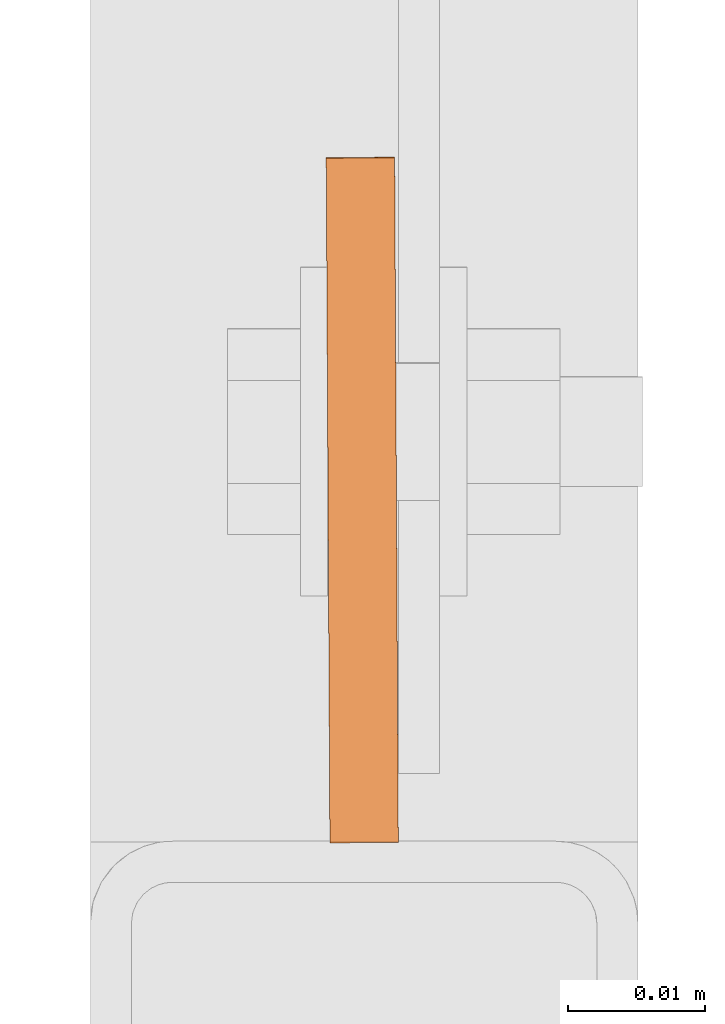
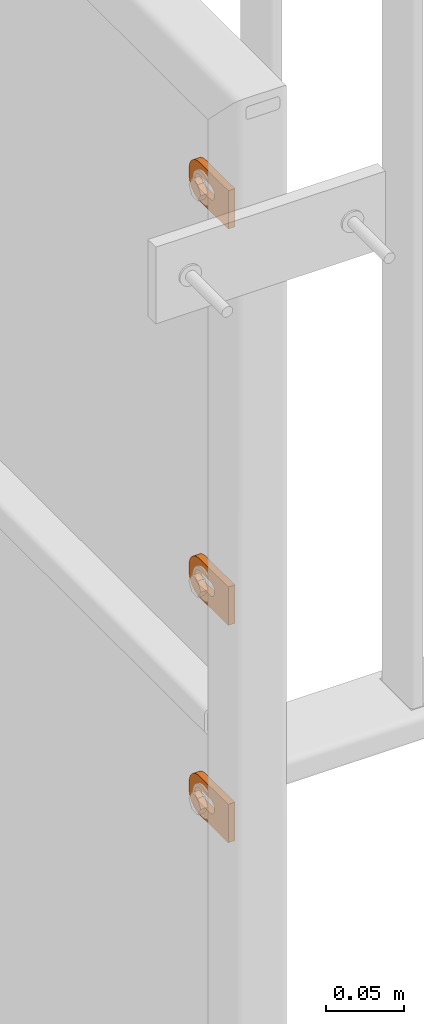
# One storey, part 141 of 156: 3 proxies, 1 element without a shape of its own.
"""IFC2X3 building model written with IfcOpenShell, lengths in millimetres."""

from ifc_helpers import new_model, si_unit, frame, origin_with_axes, place, context, subcontext, project, spatial, faceted_brep, material, type_object, element, aggregate, save


model = new_model("IFC2X3")

# Units and contexts
model_context = context("Model", 3, precision=1e-05, world=origin_with_axes())
body_context = subcontext(model_context, "Body", "Model", "MODEL_VIEW")
ifc_project = project(units=[si_unit("LENGTHUNIT", "METRE", prefix="MILLI"), si_unit("AREAUNIT", "SQUARE_METRE"), si_unit("VOLUMEUNIT", "CUBIC_METRE"), si_unit("MASSUNIT", "GRAM", prefix="KILO"), si_unit("TIMEUNIT", "SECOND"), si_unit("PLANEANGLEUNIT", "RADIAN"), si_unit("SOLIDANGLEUNIT", "STERADIAN"), si_unit("THERMODYNAMICTEMPERATUREUNIT", "DEGREE_CELSIUS"), si_unit("LUMINOUSINTENSITYUNIT", "LUMEN")], contexts=[model_context])

# Site, building, storey
site_placement = place(None, origin_with_axes())
site = spatial("IfcSite", under=ifc_project, at=site_placement, CompositionType="ELEMENT")
building_placement = place(site_placement, origin_with_axes())
building = spatial("IfcBuilding", under=site, at=building_placement, Name="Undefined", CompositionType="ELEMENT")
storey_placement = place(building_placement, origin_with_axes())
storey = spatial("IfcBuildingStorey", under=building, at=storey_placement, Name="Undefined", CompositionType="ELEMENT", Elevation=0.0)

# Assembly, proxies
assembly_placement = place(storey_placement, origin_with_axes())
assembly = element("IfcElementAssembly", 1, at=assembly_placement, inside=storey, AssemblyPlace="NOTDEFINED", PredefinedType="RIGID_FRAME")
ifc_material = material(Name="STEEL/S235JR")
building_element_proxy_type = type_object("IfcBuildingElementProxyType", Name="50", PredefinedType="NOTDEFINED")
proxy_1_placement = place(assembly_placement, frame((34000.0, 20157.8969120076, 4384.99382245688), z_axis=(0.999985556002151, 0.00537473600001249, 0.0), x_axis=(-0.00537473600001187, 0.999985556002151, 1.19999999540802e-08)))
proxy_1 = element("IfcBuildingElementProxy", 2, at=proxy_1_placement, type_object=building_element_proxy_type, material=ifc_material, ObjectType="50", CompositionType="ELEMENT", context=body_context, shape_type="Brep", body=[
    faceted_brep([(37.0000004768226, -5.50000056624776, -2.49999994410609), (23.0000000446889, -5.50000056624594, -2.49999994410973), (23.0000000446889, -5.50000056624594, 2.49999994413156), (37.000000476819, -5.50000056624776, 2.49999994413338), (21.9270028173814, -5.39431966841403, -2.49999994410973), (21.9270028173778, -5.39431966841403, 2.49999994412792), (20.895240828384, -5.0813375413436, -2.49999994411155), (20.895240828384, -5.0813375413436, 2.49999994412974), (19.9443642049955, -4.5730831474084, -2.49999994410973), (19.9443642049919, -4.5730831474084, 2.49999994412792), (19.1109124571012, -3.88908818364325, -2.49999994411155), (19.1109124571012, -3.88908818364325, 2.49999994412792), (18.4269174933361, -3.05563643574806, -2.49999994411155), (18.4269174933361, -3.05563643574806, 2.4999999441261), (17.9186630994009, -2.1047579497108, -2.49999994411155), (17.9186630994009, -2.1047579497108, 2.49999994412428), (17.6056809723377, -1.07299596071425, -2.49999994411337), (17.6056809723341, -1.07299596071425, 2.4999999441261), (17.5000000745022, 3.3527521736687e-07, -2.49999994411519), (17.5000000745058, 3.3527521736687e-07, 2.49999994412428), (17.6056809723377, 1.07299663126287, -2.49999994411701), (17.6056809723377, 1.07299663126287, 2.49999994412428), (17.9186630994154, 2.10475862026124, -2.49999994411701), (17.9186630994118, 2.10475862026124, 2.49999994412246), (18.426917493347, 3.05563617497592, -2.49999994411701), (18.426917493347, 3.05563617497592, 2.49999994412246), (19.1109124571158, 3.88908699154672, -2.49999994411883), (19.1109124571121, 3.88908699154672, 2.49999994412065), (19.9443642050101, 4.57308288663444, -2.49999994411701), (19.9443642050064, 4.57308288663444, 2.49999994412065), (20.8952408283985, 5.08133728056964, -2.49999994411883), (20.8952408283985, 5.08133728056964, 2.49999994412065), (21.9270028173996, 5.39431940764007, -2.49999994411883), (21.927002817396, 5.39431940764007, 2.49999994412065), (23.0000000447108, 5.50000030547199, -2.49999994411883), (23.0000000447071, 5.50000030547199, 2.49999994412246), (37.0000004768408, 5.50000030547017, -2.49999994411519), (37.0000004768408, 5.50000030547017, 2.49999994412428), (38.0729958415031, 5.39431940763825, -2.49999994411519), (38.0729958414995, 5.39431940763825, 2.49999994412428), (39.1047596931458, 5.08133728056691, -2.49999994411337), (39.1047596931421, 5.08133728056691, 2.49999994412428), (40.0556363165415, 4.57308288663171, -2.49999994411519), (40.0556363165379, 4.57308288663171, 2.4999999441261), (40.8890880644285, 3.8890869915449, -2.49999994411337), (40.8890880644285, 3.8890869915449, 2.49999994412792), (41.5730811655449, 3.05563617497228, -2.49999994411337), (41.5730811655449, 3.05563617497228, 2.4999999441261), (42.0813374221252, 2.1047586202576, -2.49999994411155), (42.0813374221252, 2.1047586202576, 2.49999994412792), (42.3943176865469, 1.07299663126014, -2.49999994410973), (42.3943176865469, 1.07299663126014, 2.49999994412974), (42.5000004470239, 3.35271579388063e-07, -2.49999994410973), (42.5000004470276, 3.35271579388063e-07, 2.49999994412974), (42.3943176865469, -1.07299596071698, -2.49999994410791), (42.3943176865432, -1.07299596071698, 2.49999994413156), (42.0813374221179, -2.10475794971444, -2.49999994410791), (42.0813374221143, -2.10475794971444, 2.49999994413338), (41.5730811655376, -3.05563643575169, -2.49999994410791), (41.5730811655339, -3.05563643575169, 2.49999994413156), (40.8890880644176, -3.88908818364507, -2.49999994410609), (40.889088064414, -3.88908818364507, 2.49999994413338), (40.0556363165233, -4.57308314741113, -2.49999994410791), (40.0556363165233, -4.57308314741113, 2.49999994413338), (39.1047596931276, -5.08133754134633, -2.49999994410609), (39.1047596931276, -5.08133754134633, 2.49999994413338), (38.072995841485, -5.39431966841585, -2.49999994410609), (38.072995841485, -5.39431966841585, 2.49999994413156), (37.0000004768044, -14.9999993294514, 2.49999994414065), (39.5361743867034, -14.7502093017147, 2.49999994414065), (41.9748835265273, -14.0104337036646, 2.49999994414065), (44.222414493528, -12.8091058135078, 2.49999994414247), (46.192388981548, -11.1923875659759, 2.49999994413884), (47.809105366443, -9.22241307795593, 2.49999994413884), (49.010433256597, -6.97488397360394, 2.49999994413702), (49.7502088546535, -4.53617483378002, 2.49999994413338), (50.0000007450435, -2.00000092387745, 2.49999994413338), (50.0000007450471, 1.99999973177364, 2.49999994412974), (49.7502088546717, 4.53617457299879, 2.4999999441261), (49.0104332566261, 6.97488464414528, 2.4999999441261), (47.8091053664721, 9.2224128171747, 2.49999994412428), (46.192388981588, 11.1923882365172, 2.49999994412065), (44.2224144935717, 12.8091048542365, 2.49999994411883), (41.9748835265782, 14.0104339085483, 2.49999994411883), (39.5361743867543, 14.7502086334816, 2.49999994411701), (37.0000004768553, 14.9999999999964, 2.49999994411519), (2.91038304567337e-11, 15.0000000000009, 2.49999994410791), (-2.18278728425503e-11, -14.9999993294468, 2.49999994413338), (3.27418092638254e-11, 15.0000000000009, -2.49999994413156), (-2.18278728425503e-11, -14.9999993294468, -2.49999994410791), (37.0000004768008, -14.9999993294514, -2.49999994409882), (39.5361743867034, -14.7502093017147, -2.49999994409882), (41.9748835265309, -14.0104337036646, -2.499999944097), (44.222414493528, -12.8091058135078, -2.49999994409882), (46.1923889815516, -11.1923875659759, -2.49999994409882), (47.8091053664393, -9.22241307795593, -2.49999994410064), (49.0104332566007, -6.97488397360394, -2.49999994410246), (49.7502088546535, -4.53617483378002, -2.49999994410609), (50.0000007450435, -2.00000092387745, -2.49999994410609), (50.0000007450508, 1.99999973177364, -2.49999994410973), (49.750208854668, 4.53617457299879, -2.49999994411155), (49.0104332566261, 6.97488464414528, -2.49999994411337), (47.8091053664721, 9.2224128171747, -2.49999994411519), (46.1923889815916, 11.1923882365172, -2.49999994411883), (44.2224144935717, 12.8091048542365, -2.49999994411883), (41.9748835265782, 14.0104339085483, -2.49999994412065), (39.5361743867579, 14.7502086334816, -2.49999994412246), (37.000000476859, 14.9999999999964, -2.49999994412428)], [[[0, 1, 2, 3]], [[1, 4, 5, 2]], [[4, 6, 7, 5]], [[6, 8, 9, 7]], [[8, 10, 11, 9]], [[10, 12, 13, 11]], [[12, 14, 15, 13]], [[14, 16, 17, 15]], [[16, 18, 19, 17]], [[18, 20, 21, 19]], [[20, 22, 23, 21]], [[22, 24, 25, 23]], [[24, 26, 27, 25]], [[26, 28, 29, 27]], [[28, 30, 31, 29]], [[30, 32, 33, 31]], [[32, 34, 35, 33]], [[34, 36, 37, 35]], [[36, 38, 39, 37]], [[38, 40, 41, 39]], [[40, 42, 43, 41]], [[42, 44, 45, 43]], [[44, 46, 47, 45]], [[46, 48, 49, 47]], [[48, 50, 51, 49]], [[50, 52, 53, 51]], [[52, 54, 55, 53]], [[54, 56, 57, 55]], [[56, 58, 59, 57]], [[58, 60, 61, 59]], [[60, 62, 63, 61]], [[62, 64, 65, 63]], [[64, 66, 67, 65]], [[66, 0, 3, 67]], [[68, 69, 70, 71, 72, 73, 74, 75, 76, 77, 78, 79, 80, 81, 82, 83, 84, 85, 86, 87], [5, 7, 9, 11, 13, 15, 17, 19, 21, 23, 25, 27, 29, 31, 33, 35, 37, 39, 41, 43, 45, 47, 49, 51, 53, 55, 57, 59, 61, 63, 65, 67, 3, 2]], [[86, 88, 89, 87]], [[87, 89, 90, 68]], [[68, 90, 91, 69]], [[69, 91, 92, 70]], [[70, 92, 93, 71]], [[71, 93, 94, 72]], [[72, 94, 95, 73]], [[73, 95, 96, 74]], [[74, 96, 97, 75]], [[75, 97, 98, 76]], [[76, 98, 99, 77]], [[77, 99, 100, 78]], [[78, 100, 101, 79]], [[79, 101, 102, 80]], [[80, 102, 103, 81]], [[81, 103, 104, 82]], [[82, 104, 105, 83]], [[83, 105, 106, 84]], [[84, 106, 107, 85]], [[85, 107, 88, 86]], [[105, 104, 103, 102, 101, 100, 99, 98, 97, 96, 95, 94, 93, 92, 91, 90, 89, 88, 107, 106], [60, 58, 56, 54, 52, 50, 48, 46, 44, 42, 40, 38, 36, 34, 32, 30, 28, 26, 24, 22, 20, 18, 16, 14, 12, 10, 8, 6, 4, 1, 0, 66, 64, 62]]]),
])
proxy_2_placement = place(assembly_placement, frame((34000.0, 20157.9576678345, 4075.00088546626), z_axis=(0.999985556002151, 0.00537473600001249, 0.0), x_axis=(-0.00537473600001187, 0.999985556002151, 1.19999999540802e-08)))
proxy_2 = element("IfcBuildingElementProxy", 3, at=proxy_2_placement, type_object=building_element_proxy_type, material=ifc_material, ObjectType="50", CompositionType="ELEMENT", context=body_context, shape_type="Brep", body=[
    faceted_brep([(37.0000004768226, -5.50000056624776, -2.49999994410609), (23.0000000446889, -5.50000056624594, -2.49999994410973), (23.0000000446889, -5.50000056624594, 2.49999994413156), (37.000000476819, -5.50000056624776, 2.49999994413338), (21.9270028173814, -5.39431966841403, -2.49999994410973), (21.9270028173778, -5.39431966841403, 2.49999994412792), (20.895240828384, -5.0813375413436, -2.49999994411155), (20.895240828384, -5.0813375413436, 2.49999994412974), (19.9443642049955, -4.5730831474084, -2.49999994410973), (19.9443642049919, -4.5730831474084, 2.49999994412792), (19.1109124571012, -3.88908818364325, -2.49999994411155), (19.1109124571012, -3.88908818364325, 2.49999994412792), (18.4269174933361, -3.05563643574806, -2.49999994411155), (18.4269174933361, -3.05563643574806, 2.4999999441261), (17.9186630994009, -2.1047579497108, -2.49999994411155), (17.9186630994009, -2.1047579497108, 2.49999994412428), (17.6056809723377, -1.07299596071425, -2.49999994411337), (17.6056809723341, -1.07299596071425, 2.4999999441261), (17.5000000745022, 3.3527521736687e-07, -2.49999994411519), (17.5000000745058, 3.3527521736687e-07, 2.49999994412428), (17.6056809723377, 1.07299663126287, -2.49999994411701), (17.6056809723377, 1.07299663126287, 2.49999994412428), (17.9186630994154, 2.10475862026124, -2.49999994411701), (17.9186630994118, 2.10475862026124, 2.49999994412246), (18.426917493347, 3.05563617497592, -2.49999994411701), (18.426917493347, 3.05563617497592, 2.49999994412246), (19.1109124571158, 3.88908699154672, -2.49999994411883), (19.1109124571121, 3.88908699154672, 2.49999994412065), (19.9443642050101, 4.57308288663444, -2.49999994411701), (19.9443642050064, 4.57308288663444, 2.49999994412065), (20.8952408283985, 5.08133728056964, -2.49999994411883), (20.8952408283985, 5.08133728056964, 2.49999994412065), (21.9270028173996, 5.39431940764007, -2.49999994411883), (21.927002817396, 5.39431940764007, 2.49999994412065), (23.0000000447108, 5.50000030547199, -2.49999994411883), (23.0000000447071, 5.50000030547199, 2.49999994412246), (37.0000004768408, 5.50000030547017, -2.49999994411519), (37.0000004768408, 5.50000030547017, 2.49999994412428), (38.0729958415031, 5.39431940763825, -2.49999994411519), (38.0729958414995, 5.39431940763825, 2.49999994412428), (39.1047596931458, 5.08133728056691, -2.49999994411337), (39.1047596931421, 5.08133728056691, 2.49999994412428), (40.0556363165415, 4.57308288663171, -2.49999994411519), (40.0556363165379, 4.57308288663171, 2.4999999441261), (40.8890880644285, 3.8890869915449, -2.49999994411337), (40.8890880644285, 3.8890869915449, 2.49999994412792), (41.5730811655449, 3.05563617497228, -2.49999994411337), (41.5730811655449, 3.05563617497228, 2.4999999441261), (42.0813374221252, 2.1047586202576, -2.49999994411155), (42.0813374221252, 2.1047586202576, 2.49999994412792), (42.3943176865469, 1.07299663126014, -2.49999994410973), (42.3943176865469, 1.07299663126014, 2.49999994412974), (42.5000004470239, 3.35271579388063e-07, -2.49999994410973), (42.5000004470276, 3.35271579388063e-07, 2.49999994412974), (42.3943176865469, -1.07299596071698, -2.49999994410791), (42.3943176865432, -1.07299596071698, 2.49999994413156), (42.0813374221179, -2.10475794971444, -2.49999994410791), (42.0813374221143, -2.10475794971444, 2.49999994413338), (41.5730811655376, -3.05563643575169, -2.49999994410791), (41.5730811655339, -3.05563643575169, 2.49999994413156), (40.8890880644176, -3.88908818364507, -2.49999994410609), (40.889088064414, -3.88908818364507, 2.49999994413338), (40.0556363165233, -4.57308314741113, -2.49999994410791), (40.0556363165233, -4.57308314741113, 2.49999994413338), (39.1047596931276, -5.08133754134633, -2.49999994410609), (39.1047596931276, -5.08133754134633, 2.49999994413338), (38.072995841485, -5.39431966841585, -2.49999994410609), (38.072995841485, -5.39431966841585, 2.49999994413156), (37.0000004768044, -14.9999993294514, 2.49999994414065), (39.5361743867034, -14.7502093017147, 2.49999994414065), (41.9748835265273, -14.0104337036646, 2.49999994414065), (44.222414493528, -12.8091058135078, 2.49999994414247), (46.192388981548, -11.1923875659759, 2.49999994413884), (47.809105366443, -9.22241307795593, 2.49999994413884), (49.010433256597, -6.97488397360394, 2.49999994413702), (49.7502088546535, -4.53617483378002, 2.49999994413338), (50.0000007450435, -2.00000092387745, 2.49999994413338), (50.0000007450471, 1.99999973177364, 2.49999994412974), (49.7502088546717, 4.53617457299879, 2.4999999441261), (49.0104332566261, 6.97488464414528, 2.4999999441261), (47.8091053664721, 9.2224128171747, 2.49999994412428), (46.192388981588, 11.1923882365172, 2.49999994412065), (44.2224144935717, 12.8091048542365, 2.49999994411883), (41.9748835265782, 14.0104339085483, 2.49999994411883), (39.5361743867543, 14.7502086334816, 2.49999994411701), (37.0000004768553, 14.9999999999964, 2.49999994411519), (2.91038304567337e-11, 15.0000000000009, 2.49999994410791), (-2.18278728425503e-11, -14.9999993294468, 2.49999994413338), (3.27418092638254e-11, 15.0000000000009, -2.49999994413156), (-2.18278728425503e-11, -14.9999993294468, -2.49999994410791), (37.0000004768008, -14.9999993294514, -2.49999994409882), (39.5361743867034, -14.7502093017147, -2.49999994409882), (41.9748835265309, -14.0104337036646, -2.499999944097), (44.222414493528, -12.8091058135078, -2.49999994409882), (46.1923889815516, -11.1923875659759, -2.49999994409882), (47.8091053664393, -9.22241307795593, -2.49999994410064), (49.0104332566007, -6.97488397360394, -2.49999994410246), (49.7502088546535, -4.53617483378002, -2.49999994410609), (50.0000007450435, -2.00000092387745, -2.49999994410609), (50.0000007450508, 1.99999973177364, -2.49999994410973), (49.750208854668, 4.53617457299879, -2.49999994411155), (49.0104332566261, 6.97488464414528, -2.49999994411337), (47.8091053664721, 9.2224128171747, -2.49999994411519), (46.1923889815916, 11.1923882365172, -2.49999994411883), (44.2224144935717, 12.8091048542365, -2.49999994411883), (41.9748835265782, 14.0104339085483, -2.49999994412065), (39.5361743867579, 14.7502086334816, -2.49999994412246), (37.000000476859, 14.9999999999964, -2.49999994412428)], [[[0, 1, 2, 3]], [[1, 4, 5, 2]], [[4, 6, 7, 5]], [[6, 8, 9, 7]], [[8, 10, 11, 9]], [[10, 12, 13, 11]], [[12, 14, 15, 13]], [[14, 16, 17, 15]], [[16, 18, 19, 17]], [[18, 20, 21, 19]], [[20, 22, 23, 21]], [[22, 24, 25, 23]], [[24, 26, 27, 25]], [[26, 28, 29, 27]], [[28, 30, 31, 29]], [[30, 32, 33, 31]], [[32, 34, 35, 33]], [[34, 36, 37, 35]], [[36, 38, 39, 37]], [[38, 40, 41, 39]], [[40, 42, 43, 41]], [[42, 44, 45, 43]], [[44, 46, 47, 45]], [[46, 48, 49, 47]], [[48, 50, 51, 49]], [[50, 52, 53, 51]], [[52, 54, 55, 53]], [[54, 56, 57, 55]], [[56, 58, 59, 57]], [[58, 60, 61, 59]], [[60, 62, 63, 61]], [[62, 64, 65, 63]], [[64, 66, 67, 65]], [[66, 0, 3, 67]], [[68, 69, 70, 71, 72, 73, 74, 75, 76, 77, 78, 79, 80, 81, 82, 83, 84, 85, 86, 87], [5, 7, 9, 11, 13, 15, 17, 19, 21, 23, 25, 27, 29, 31, 33, 35, 37, 39, 41, 43, 45, 47, 49, 51, 53, 55, 57, 59, 61, 63, 65, 67, 3, 2]], [[86, 88, 89, 87]], [[87, 89, 90, 68]], [[68, 90, 91, 69]], [[69, 91, 92, 70]], [[70, 92, 93, 71]], [[71, 93, 94, 72]], [[72, 94, 95, 73]], [[73, 95, 96, 74]], [[74, 96, 97, 75]], [[75, 97, 98, 76]], [[76, 98, 99, 77]], [[77, 99, 100, 78]], [[78, 100, 101, 79]], [[79, 101, 102, 80]], [[80, 102, 103, 81]], [[81, 103, 104, 82]], [[82, 104, 105, 83]], [[83, 105, 106, 84]], [[84, 106, 107, 85]], [[85, 107, 88, 86]], [[105, 104, 103, 102, 101, 100, 99, 98, 97, 96, 95, 94, 93, 92, 91, 90, 89, 88, 107, 106], [60, 58, 56, 54, 52, 50, 48, 46, 44, 42, 40, 38, 36, 34, 32, 30, 28, 26, 24, 22, 20, 18, 16, 14, 12, 10, 8, 6, 4, 1, 0, 66, 64, 62]]]),
])
proxy_3_placement = place(assembly_placement, frame((34000.0, 20157.9563390375, 3904.98209838867), z_axis=(0.999985556002151, 0.00537473600001249, 0.0), x_axis=(-0.00537473600001187, 0.999985556002151, 1.19999999540802e-08)))
proxy_3 = element("IfcBuildingElementProxy", 4, at=proxy_3_placement, type_object=building_element_proxy_type, material=ifc_material, ObjectType="50", CompositionType="ELEMENT", context=body_context, shape_type="Brep", body=[
    faceted_brep([(37.0000004768226, -5.50000056624776, -2.49999994410609), (23.0000000446889, -5.50000056624594, -2.49999994410973), (23.0000000446889, -5.50000056624594, 2.49999994413156), (37.000000476819, -5.50000056624776, 2.49999994413338), (21.9270028173814, -5.39431966841403, -2.49999994410973), (21.9270028173778, -5.39431966841403, 2.49999994412792), (20.895240828384, -5.0813375413436, -2.49999994411155), (20.895240828384, -5.0813375413436, 2.49999994412974), (19.9443642049955, -4.5730831474084, -2.49999994410973), (19.9443642049919, -4.5730831474084, 2.49999994412792), (19.1109124571012, -3.88908818364325, -2.49999994411155), (19.1109124571012, -3.88908818364325, 2.49999994412792), (18.4269174933361, -3.05563643574806, -2.49999994411155), (18.4269174933361, -3.05563643574806, 2.4999999441261), (17.9186630994009, -2.1047579497108, -2.49999994411155), (17.9186630994009, -2.1047579497108, 2.49999994412428), (17.6056809723377, -1.07299596071425, -2.49999994411337), (17.6056809723341, -1.07299596071425, 2.4999999441261), (17.5000000745022, 3.3527521736687e-07, -2.49999994411519), (17.5000000745058, 3.3527521736687e-07, 2.49999994412428), (17.6056809723377, 1.07299663126287, -2.49999994411701), (17.6056809723377, 1.07299663126287, 2.49999994412428), (17.9186630994154, 2.10475862026124, -2.49999994411701), (17.9186630994118, 2.10475862026124, 2.49999994412246), (18.426917493347, 3.05563617497592, -2.49999994411701), (18.426917493347, 3.05563617497592, 2.49999994412246), (19.1109124571158, 3.88908699154672, -2.49999994411883), (19.1109124571121, 3.88908699154672, 2.49999994412065), (19.9443642050101, 4.57308288663444, -2.49999994411701), (19.9443642050064, 4.57308288663444, 2.49999994412065), (20.8952408283985, 5.08133728056964, -2.49999994411883), (20.8952408283985, 5.08133728056964, 2.49999994412065), (21.9270028173996, 5.39431940764007, -2.49999994411883), (21.927002817396, 5.39431940764007, 2.49999994412065), (23.0000000447108, 5.50000030547199, -2.49999994411883), (23.0000000447071, 5.50000030547199, 2.49999994412246), (37.0000004768408, 5.50000030547017, -2.49999994411519), (37.0000004768408, 5.50000030547017, 2.49999994412428), (38.0729958415031, 5.39431940763825, -2.49999994411519), (38.0729958414995, 5.39431940763825, 2.49999994412428), (39.1047596931458, 5.08133728056691, -2.49999994411337), (39.1047596931421, 5.08133728056691, 2.49999994412428), (40.0556363165415, 4.57308288663171, -2.49999994411519), (40.0556363165379, 4.57308288663171, 2.4999999441261), (40.8890880644285, 3.8890869915449, -2.49999994411337), (40.8890880644285, 3.8890869915449, 2.49999994412792), (41.5730811655449, 3.05563617497228, -2.49999994411337), (41.5730811655449, 3.05563617497228, 2.4999999441261), (42.0813374221252, 2.1047586202576, -2.49999994411155), (42.0813374221252, 2.1047586202576, 2.49999994412792), (42.3943176865469, 1.07299663126014, -2.49999994410973), (42.3943176865469, 1.07299663126014, 2.49999994412974), (42.5000004470239, 3.35271579388063e-07, -2.49999994410973), (42.5000004470276, 3.35271579388063e-07, 2.49999994412974), (42.3943176865469, -1.07299596071698, -2.49999994410791), (42.3943176865432, -1.07299596071698, 2.49999994413156), (42.0813374221179, -2.10475794971444, -2.49999994410791), (42.0813374221143, -2.10475794971444, 2.49999994413338), (41.5730811655376, -3.05563643575169, -2.49999994410791), (41.5730811655339, -3.05563643575169, 2.49999994413156), (40.8890880644176, -3.88908818364507, -2.49999994410609), (40.889088064414, -3.88908818364507, 2.49999994413338), (40.0556363165233, -4.57308314741113, -2.49999994410791), (40.0556363165233, -4.57308314741113, 2.49999994413338), (39.1047596931276, -5.08133754134633, -2.49999994410609), (39.1047596931276, -5.08133754134633, 2.49999994413338), (38.072995841485, -5.39431966841585, -2.49999994410609), (38.072995841485, -5.39431966841585, 2.49999994413156), (37.0000004768044, -14.9999993294514, 2.49999994414065), (39.5361743867034, -14.7502093017147, 2.49999994414065), (41.9748835265273, -14.0104337036646, 2.49999994414065), (44.222414493528, -12.8091058135078, 2.49999994414247), (46.192388981548, -11.1923875659759, 2.49999994413884), (47.809105366443, -9.22241307795593, 2.49999994413884), (49.010433256597, -6.97488397360394, 2.49999994413702), (49.7502088546535, -4.53617483378002, 2.49999994413338), (50.0000007450435, -2.00000092387745, 2.49999994413338), (50.0000007450471, 1.99999973177364, 2.49999994412974), (49.7502088546717, 4.53617457299879, 2.4999999441261), (49.0104332566261, 6.97488464414528, 2.4999999441261), (47.8091053664721, 9.2224128171747, 2.49999994412428), (46.192388981588, 11.1923882365172, 2.49999994412065), (44.2224144935717, 12.8091048542365, 2.49999994411883), (41.9748835265782, 14.0104339085483, 2.49999994411883), (39.5361743867543, 14.7502086334816, 2.49999994411701), (37.0000004768553, 14.9999999999964, 2.49999994411519), (2.91038304567337e-11, 15.0000000000009, 2.49999994410791), (-2.18278728425503e-11, -14.9999993294468, 2.49999994413338), (3.27418092638254e-11, 15.0000000000009, -2.49999994413156), (-2.18278728425503e-11, -14.9999993294468, -2.49999994410791), (37.0000004768008, -14.9999993294514, -2.49999994409882), (39.5361743867034, -14.7502093017147, -2.49999994409882), (41.9748835265309, -14.0104337036646, -2.499999944097), (44.222414493528, -12.8091058135078, -2.49999994409882), (46.1923889815516, -11.1923875659759, -2.49999994409882), (47.8091053664393, -9.22241307795593, -2.49999994410064), (49.0104332566007, -6.97488397360394, -2.49999994410246), (49.7502088546535, -4.53617483378002, -2.49999994410609), (50.0000007450435, -2.00000092387745, -2.49999994410609), (50.0000007450508, 1.99999973177364, -2.49999994410973), (49.750208854668, 4.53617457299879, -2.49999994411155), (49.0104332566261, 6.97488464414528, -2.49999994411337), (47.8091053664721, 9.2224128171747, -2.49999994411519), (46.1923889815916, 11.1923882365172, -2.49999994411883), (44.2224144935717, 12.8091048542365, -2.49999994411883), (41.9748835265782, 14.0104339085483, -2.49999994412065), (39.5361743867579, 14.7502086334816, -2.49999994412246), (37.000000476859, 14.9999999999964, -2.49999994412428)], [[[0, 1, 2, 3]], [[1, 4, 5, 2]], [[4, 6, 7, 5]], [[6, 8, 9, 7]], [[8, 10, 11, 9]], [[10, 12, 13, 11]], [[12, 14, 15, 13]], [[14, 16, 17, 15]], [[16, 18, 19, 17]], [[18, 20, 21, 19]], [[20, 22, 23, 21]], [[22, 24, 25, 23]], [[24, 26, 27, 25]], [[26, 28, 29, 27]], [[28, 30, 31, 29]], [[30, 32, 33, 31]], [[32, 34, 35, 33]], [[34, 36, 37, 35]], [[36, 38, 39, 37]], [[38, 40, 41, 39]], [[40, 42, 43, 41]], [[42, 44, 45, 43]], [[44, 46, 47, 45]], [[46, 48, 49, 47]], [[48, 50, 51, 49]], [[50, 52, 53, 51]], [[52, 54, 55, 53]], [[54, 56, 57, 55]], [[56, 58, 59, 57]], [[58, 60, 61, 59]], [[60, 62, 63, 61]], [[62, 64, 65, 63]], [[64, 66, 67, 65]], [[66, 0, 3, 67]], [[68, 69, 70, 71, 72, 73, 74, 75, 76, 77, 78, 79, 80, 81, 82, 83, 84, 85, 86, 87], [5, 7, 9, 11, 13, 15, 17, 19, 21, 23, 25, 27, 29, 31, 33, 35, 37, 39, 41, 43, 45, 47, 49, 51, 53, 55, 57, 59, 61, 63, 65, 67, 3, 2]], [[86, 88, 89, 87]], [[87, 89, 90, 68]], [[68, 90, 91, 69]], [[69, 91, 92, 70]], [[70, 92, 93, 71]], [[71, 93, 94, 72]], [[72, 94, 95, 73]], [[73, 95, 96, 74]], [[74, 96, 97, 75]], [[75, 97, 98, 76]], [[76, 98, 99, 77]], [[77, 99, 100, 78]], [[78, 100, 101, 79]], [[79, 101, 102, 80]], [[80, 102, 103, 81]], [[81, 103, 104, 82]], [[82, 104, 105, 83]], [[83, 105, 106, 84]], [[84, 106, 107, 85]], [[85, 107, 88, 86]], [[105, 104, 103, 102, 101, 100, 99, 98, 97, 96, 95, 94, 93, 92, 91, 90, 89, 88, 107, 106], [60, 58, 56, 54, 52, 50, 48, 46, 44, 42, 40, 38, 36, 34, 32, 30, 28, 26, 24, 22, 20, 18, 16, 14, 12, 10, 8, 6, 4, 1, 0, 66, 64, 62]]]),
])
aggregate(assembly, [proxy_1, proxy_2, proxy_3])

save(model, "model.ifc")
